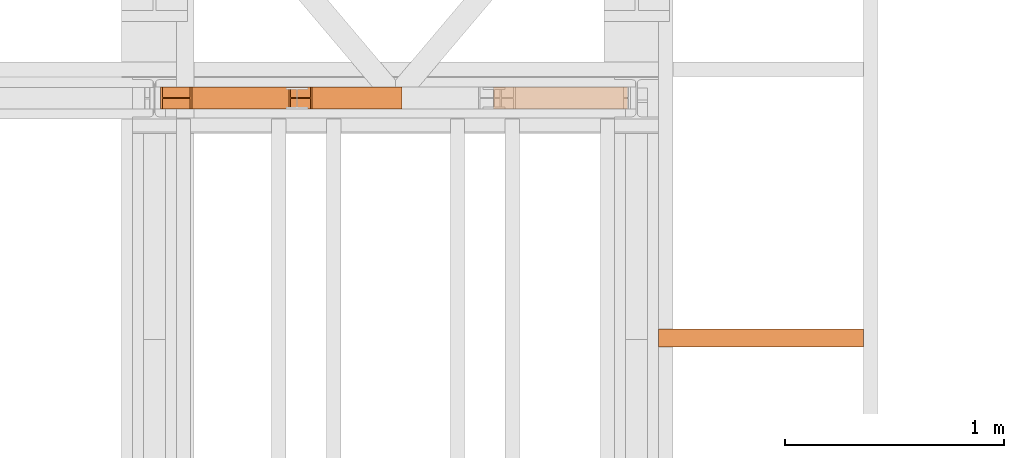
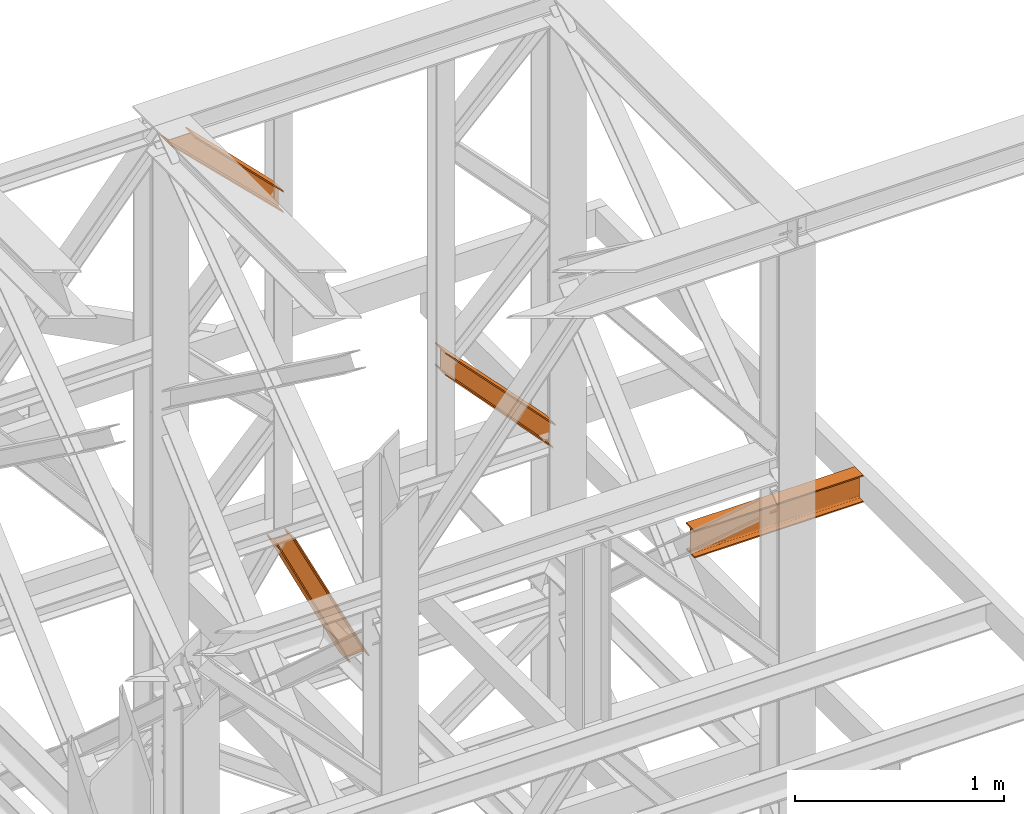
# One storey, part 206 of 208: 4 proxies.
"""IFC2X3 building model written with IfcOpenShell, lengths in millimetres."""

from ifc_helpers import new_model, entity, si_unit, converted_unit, frame, origin, origin_with_axes, place, context, subcontext, project, spatial, faceted_brep, element, save


model = new_model("IFC2X3")

# Units and contexts
model_context = context("Model", 3, precision=1e-05, world=origin())
plan_context = context("Plan", 3, precision=1e-05, world=origin())
body_context = subcontext(model_context, "Body", "Model", "MODEL_VIEW")
ifc_project = project(units=[si_unit("LENGTHUNIT", "METRE", prefix="MILLI"), converted_unit("PLANEANGLEUNIT", "DEGREE", entity("IfcPlaneAngleMeasure", 0.0174532925199433), si_unit("PLANEANGLEUNIT", "RADIAN"), dimensions=[0, 0, 0, 0, 0, 0, 0]), si_unit("AREAUNIT", "SQUARE_METRE"), si_unit("VOLUMEUNIT", "CUBIC_METRE")], contexts=[model_context, plan_context])

# Building, storey
building_placement = place(None, origin())
building = spatial("IfcBuilding", under=ifc_project, at=building_placement, CompositionType="COMPLEX")
storey_placement = place(building_placement, origin_with_axes())
storey = spatial("IfcBuildingStorey", under=building, at=storey_placement, Name="Geschoss", CompositionType="ELEMENT")

# Proxies
proxy_1_placement = place(storey_placement, frame((8140.754968528663, -13810.57439404318, 9738.383764068489), z_axis=(0.0, 0.0, 1.0), x_axis=(1.0, 0.0, 0.0)))
element("IfcBuildingElementProxy", 1, at=proxy_1_placement, inside=storey, context=body_context, shape_type="Brep", body=[
    faceted_brep([(609.3389392297795, 0.01000000000021828, 127.1336120970282), (0.01000000000203727, 0.01000000000021828, 762.0805165043985), (0.01000000000203727, 0.01000000000021828, 772.1793707618835), (610.1904194102481, 0.01000000000021828, 135.4554138886069), (610.1904194102481, 0.01000000000021828, 135.4554138886069), (0.01000000000203727, 0.01000000000021828, 772.1793707618835), (0.01000000000294676, 100.0100000000002, 772.1793707618799), (610.1904194102481, 100.0100000000002, 135.4554138886069), (610.1904194102481, 100.0100000000002, 135.4554138886069), (0.01000000000294676, 100.0100000000002, 772.1793707618799), (0.01000000000203727, 100.0100000000002, 762.0805165043985), (609.3389392297795, 100.0100000000002, 127.1336120970282), (609.3389392297795, 100.0100000000002, 127.1336120970282), (0.01000000000203727, 100.0100000000002, 762.0805165043985), (0.01000000000203727, 52.51000000000022, 762.0805165043985), (609.3389392297795, 52.51000000000022, 127.1336120970282), (609.3389392297795, 52.51000000000022, 127.1336120970282), (0.01000000000203727, 52.51000000000022, 762.0805165043985), (0.01000000000112777, 52.51000000000022, 645.5811508176976), (597.1830768457185, 52.51000000000022, 8.330286210673876), (597.1830768457185, 52.51000000000022, 8.330286210673876), (0.01000000000112777, 52.51000000000022, 645.5811508176976), (0.009999999999308784, 100.0100000000002, 645.5811508177048), (597.1830768457185, 100.0100000000002, 8.330286210677514), (597.1830768457185, 100.0100000000002, 8.330286210677514), (0.009999999999308784, 100.0100000000002, 645.5811508177048), (0.01000000000203727, 100.0100000000002, 635.4780302121417), (596.3317517382911, 100.0100000000002, 0.01000000000021828), (596.3317517382911, 100.0100000000002, 0.01000000000021828), (0.01000000000203727, 100.0100000000002, 635.4780302121417), (0.01000000000294676, 0.01000000000021828, 635.4780302121417), (596.3317517382911, 0.01000000000021828, 0.01000000000021828), (596.3317517382911, 0.01000000000021828, 0.01000000000021828), (0.01000000000294676, 0.01000000000021828, 635.4780302121417), (0.01000000000112777, 0.01000000000021828, 645.5811508177048), (597.1830768457185, 0.01000000000021828, 8.330286210677514), (597.1830768457185, 0.01000000000021828, 8.330286210677514), (0.01000000000112777, 0.01000000000021828, 645.5811508177048), (0.01000000000203727, 47.51000000000022, 645.5811508177048), (597.1830768457203, 47.51000000000022, 8.330286210681152), (597.1830768457203, 47.51000000000022, 8.330286210681152), (0.01000000000203727, 47.51000000000022, 645.5811508177048), (0.01000000000203727, 47.51000000000022, 762.0805165043985), (609.3389392297795, 47.51000000000022, 127.1336120970282), (609.3389392297795, 47.51000000000022, 127.1336120970282), (0.01000000000203727, 47.51000000000022, 762.0805165043985), (0.01000000000203727, 0.01000000000021828, 762.0805165043985), (609.3389392297795, 0.01000000000021828, 127.1336120970282), (610.1904194102481, 0.01000000000021828, 135.4554138886069), (610.1904194102481, 100.0100000000002, 135.4554138886069), (609.3389392297795, 100.0100000000002, 127.1336120970282), (609.3389392297795, 52.51000000000022, 127.1336120970282), (597.1830768457185, 52.51000000000022, 8.330286210673876), (597.1830768457185, 100.0100000000002, 8.330286210677514), (596.3317517382911, 100.0100000000002, 0.01000000000021828), (596.3317517382911, 0.01000000000021828, 0.01000000000021828), (597.1830768457185, 0.01000000000021828, 8.330286210677514), (597.1830768457203, 47.51000000000022, 8.330286210681152), (609.3389392297795, 47.51000000000022, 127.1336120970282), (609.3389392297795, 0.01000000000021828, 127.1336120970282), (0.01000000000203727, 0.01000000000021828, 762.0805165043985), (0.01000000000203727, 47.51000000000022, 762.0805165043985), (0.01000000000203727, 47.51000000000022, 645.5811508177048), (0.01000000000112777, 0.01000000000021828, 645.5811508177048), (0.01000000000294676, 0.01000000000021828, 635.4780302121417), (0.01000000000203727, 100.0100000000002, 635.4780302121417), (0.009999999999308784, 100.0100000000002, 645.5811508177048), (0.01000000000112777, 52.51000000000022, 645.5811508176976), (0.01000000000203727, 52.51000000000022, 762.0805165043985), (0.01000000000203727, 100.0100000000002, 762.0805165043985), (0.01000000000294676, 100.0100000000002, 772.1793707618799), (0.01000000000203727, 0.01000000000021828, 772.1793707618835)], [[[0, 1, 2, 3]], [[4, 5, 6, 7]], [[8, 9, 10, 11]], [[12, 13, 14, 15]], [[16, 17, 18, 19]], [[20, 21, 22, 23]], [[24, 25, 26, 27]], [[28, 29, 30, 31]], [[32, 33, 34, 35]], [[36, 37, 38, 39]], [[40, 41, 42, 43]], [[44, 45, 46, 47]], [[48, 49, 50, 51, 52, 53, 54, 55, 56, 57, 58, 59]], [[60, 61, 62, 63, 64, 65, 66, 67, 68, 69, 70, 71]]], orient=[[False], [False], [False], [False], [False], [False], [False], [False], [False], [False], [False], [False], [False], [False]]),
])
proxy_2_placement = place(storey_placement, frame((6621.102838478852, -13810.57439404318, 11640.28097264272), z_axis=(0.0, 0.0, 1.0), x_axis=(1.0, 0.0, 0.0)))
element("IfcBuildingElementProxy", 2, at=proxy_2_placement, inside=storey, context=body_context, shape_type="Brep", body=[
    faceted_brep([(134.4022503379219, 0.01000000000203727, 609.7190860510873), (143.6237680844633, 0.01000000000021828, 609.7190860510873), (622.1621300498164, 0.01000000000021828, 130.8127730178949), (622.1621300498164, 0.01000000000021828, 120.9016769489845), (143.6237680844633, 0.01000000000021828, 609.7190860510873), (143.6237680844643, 100.0100000000002, 609.7190860510873), (622.1621300498127, 100.0100000000002, 130.8127730179022), (622.1621300498164, 0.01000000000021828, 130.8127730178949), (143.6237680844643, 100.0100000000002, 609.7190860510873), (134.4022503379219, 100.0100000000002, 609.7190860510873), (622.1621300498164, 100.0100000000002, 120.9016769489845), (622.1621300498127, 100.0100000000002, 130.8127730179022), (134.4022503379219, 100.0100000000002, 609.7190860510873), (134.402250337921, 52.51000000000022, 609.7190860510873), (622.1621300498173, 52.51000000000022, 120.9016769489808), (622.1621300498164, 100.0100000000002, 120.9016769489845), (134.402250337921, 52.51000000000022, 609.7190860510873), (9.2316220054945, 52.51000000000022, 609.7190860510873), (622.1621300498164, 52.51000000000022, 9.871029833511784), (622.1621300498173, 52.51000000000022, 120.9016769489808), (9.2316220054945, 52.51000000000022, 609.7190860510873), (9.2316220054945, 100.0100000000002, 609.7190860510909), (622.1621300498164, 100.0100000000002, 9.871029833511784), (622.1621300498164, 52.51000000000022, 9.871029833511784), (9.2316220054945, 100.0100000000002, 609.7190860510909), (0.01000000000021828, 100.0100000000002, 609.7190860510909), (622.1621300498164, 100.0100000000002, 0.01000000000021828), (622.1621300498164, 100.0100000000002, 9.871029833511784), (0.01000000000021828, 100.0100000000002, 609.7190860510909), (0.01000000000476575, 0.01000000000021828, 609.7190860510837), (622.1621300498164, 0.01000000000021828, 0.01000000000021828), (622.1621300498164, 100.0100000000002, 0.01000000000021828), (0.01000000000476575, 0.01000000000021828, 609.7190860510837), (9.231622005500867, 0.01000000000203727, 609.7190860510873), (622.1621300498164, 0.01000000000021828, 9.871029833511784), (622.1621300498164, 0.01000000000021828, 0.01000000000021828), (9.231622005500867, 0.01000000000203727, 609.7190860510873), (9.231622005498139, 47.51000000000022, 609.7190860510909), (622.1621300498164, 47.51000000000022, 9.871029833511784), (622.1621300498164, 0.01000000000021828, 9.871029833511784), (9.231622005498139, 47.51000000000022, 609.7190860510909), (134.4022503379219, 47.51000000000022, 609.7190860510873), (622.1621300498164, 47.51000000000022, 120.9016769489845), (622.1621300498164, 47.51000000000022, 9.871029833511784), (134.4022503379219, 47.51000000000022, 609.7190860510873), (134.4022503379219, 0.01000000000203727, 609.7190860510873), (622.1621300498164, 0.01000000000021828, 120.9016769489845), (622.1621300498164, 47.51000000000022, 120.9016769489845), (622.1621300498164, 0.01000000000021828, 120.9016769489845), (622.1621300498164, 0.01000000000021828, 130.8127730178949), (622.1621300498127, 100.0100000000002, 130.8127730179022), (622.1621300498164, 100.0100000000002, 120.9016769489845), (622.1621300498173, 52.51000000000022, 120.9016769489808), (622.1621300498164, 52.51000000000022, 9.871029833511784), (622.1621300498164, 100.0100000000002, 9.871029833511784), (622.1621300498164, 100.0100000000002, 0.01000000000021828), (622.1621300498164, 0.01000000000021828, 0.01000000000021828), (622.1621300498164, 0.01000000000021828, 9.871029833511784), (622.1621300498164, 47.51000000000022, 9.871029833511784), (622.1621300498164, 47.51000000000022, 120.9016769489845), (143.6237680844633, 0.01000000000021828, 609.7190860510873), (134.4022503379219, 0.01000000000203727, 609.7190860510873), (134.4022503379219, 47.51000000000022, 609.7190860510873), (9.231622005498139, 47.51000000000022, 609.7190860510909), (9.231622005500867, 0.01000000000203727, 609.7190860510873), (0.01000000000476575, 0.01000000000021828, 609.7190860510837), (0.01000000000021828, 100.0100000000002, 609.7190860510909), (9.2316220054945, 100.0100000000002, 609.7190860510909), (9.2316220054945, 52.51000000000022, 609.7190860510873), (134.402250337921, 52.51000000000022, 609.7190860510873), (134.4022503379219, 100.0100000000002, 609.7190860510873), (143.6237680844643, 100.0100000000002, 609.7190860510873)], [[[0, 1, 2, 3]], [[4, 5, 6, 7]], [[8, 9, 10, 11]], [[12, 13, 14, 15]], [[16, 17, 18, 19]], [[20, 21, 22, 23]], [[24, 25, 26, 27]], [[28, 29, 30, 31]], [[32, 33, 34, 35]], [[36, 37, 38, 39]], [[40, 41, 42, 43]], [[44, 45, 46, 47]], [[48, 49, 50, 51, 52, 53, 54, 55, 56, 57, 58, 59]], [[60, 61, 62, 63, 64, 65, 66, 67, 68, 69, 70, 71]]], orient=[[False], [False], [False], [False], [False], [False], [False], [False], [False], [False], [False], [False], [False], [False]]),
])
proxy_3_placement = place(storey_placement, frame((7206.920491684339, -13810.57439404318, 8881.007354628784), z_axis=(0.0, 0.0, 1.0), x_axis=(1.0, 0.0, 0.0)))
element("IfcBuildingElementProxy", 3, at=proxy_3_placement, inside=storey, context=body_context, shape_type="Brep", body=[
    faceted_brep([(515.1363869069501, 0.01000000000021828, 0.01000000000021828), (507.9473177084756, 0.01000000000021828, 0.01000000000021828), (97.49508042920752, 0.01000000000021828, 829.1083585935612), (105.1910810543704, 0.01000000000021828, 829.1083585935612), (515.1363869069492, 100.0100000000002, 0.01000000000021828), (515.1363869069501, 0.01000000000021828, 0.01000000000021828), (105.1910810543704, 0.01000000000021828, 829.1083585935612), (105.1910810543668, 100.0100000000002, 829.1083585935612), (507.9473177084756, 100.0100000000002, 0.01000000000021828), (515.1363869069492, 100.0100000000002, 0.01000000000021828), (105.1910810543668, 100.0100000000002, 829.1083585935612), (97.49508042920752, 100.0100000000002, 829.1083585935612), (507.9473177084756, 52.51000000000022, 0.01000000000385626), (507.9473177084756, 100.0100000000002, 0.01000000000021828), (97.49508042920752, 100.0100000000002, 829.1083585935612), (97.49508042920752, 52.51000000000022, 829.1083585935612), (409.4818461420691, 52.51000000000022, 0.01000000000021828), (507.9473177084756, 52.51000000000022, 0.01000000000385626), (97.49508042920752, 52.51000000000022, 829.1083585935612), (7.688350677079143, 52.51000000000022, 829.1083585935612), (409.4818461420718, 100.0100000000002, 0.01000000000021828), (409.4818461420691, 52.51000000000022, 0.01000000000021828), (7.688350677079143, 52.51000000000022, 829.1083585935612), (7.688350677081871, 100.0100000000002, 829.1083585935612), (402.3010046401523, 100.0100000000002, 0.01000000000021828), (409.4818461420718, 100.0100000000002, 0.01000000000021828), (7.688350677081871, 100.0100000000002, 829.1083585935612), (0.01000000000021828, 100.0100000000002, 829.1083585935612), (402.3010046401523, 0.01000000000021828, 0.01000000000021828), (402.3010046401523, 100.0100000000002, 0.01000000000021828), (0.01000000000021828, 100.0100000000002, 829.1083585935612), (0.01000000000021828, 0.01000000000021828, 829.1083585935612), (409.4818461420718, 0.01000000000021828, 0.01000000000021828), (402.3010046401523, 0.01000000000021828, 0.01000000000021828), (0.01000000000021828, 0.01000000000021828, 829.1083585935612), (7.68835067708369, 0.01000000000021828, 829.1083585935612), (409.4818461420737, 47.51000000000022, 0.01000000000021828), (409.4818461420718, 0.01000000000021828, 0.01000000000021828), (7.68835067708369, 0.01000000000021828, 829.1083585935612), (7.68835067708369, 47.51000000000022, 829.1083585935612), (507.9473177084756, 47.51000000000022, 0.01000000000385626), (409.4818461420737, 47.51000000000022, 0.01000000000021828), (7.68835067708369, 47.51000000000022, 829.1083585935612), (97.49508042920752, 47.51000000000022, 829.1083585935612), (507.9473177084756, 0.01000000000021828, 0.01000000000021828), (507.9473177084756, 47.51000000000022, 0.01000000000385626), (97.49508042920752, 47.51000000000022, 829.1083585935612), (97.49508042920752, 0.01000000000021828, 829.1083585935612), (105.1910810543704, 0.01000000000021828, 829.1083585935612), (97.49508042920752, 0.01000000000021828, 829.1083585935612), (97.49508042920752, 47.51000000000022, 829.1083585935612), (7.68835067708369, 47.51000000000022, 829.1083585935612), (7.68835067708369, 0.01000000000021828, 829.1083585935612), (0.01000000000021828, 0.01000000000021828, 829.1083585935612), (0.01000000000021828, 100.0100000000002, 829.1083585935612), (7.688350677081871, 100.0100000000002, 829.1083585935612), (7.688350677079143, 52.51000000000022, 829.1083585935612), (97.49508042920752, 52.51000000000022, 829.1083585935612), (97.49508042920752, 100.0100000000002, 829.1083585935612), (105.1910810543668, 100.0100000000002, 829.1083585935612), (507.9473177084756, 0.01000000000021828, 0.01000000000021828), (515.1363869069501, 0.01000000000021828, 0.01000000000021828), (515.1363869069492, 100.0100000000002, 0.01000000000021828), (507.9473177084756, 100.0100000000002, 0.01000000000021828), (507.9473177084756, 52.51000000000022, 0.01000000000385626), (409.4818461420691, 52.51000000000022, 0.01000000000021828), (409.4818461420718, 100.0100000000002, 0.01000000000021828), (402.3010046401523, 100.0100000000002, 0.01000000000021828), (402.3010046401523, 0.01000000000021828, 0.01000000000021828), (409.4818461420718, 0.01000000000021828, 0.01000000000021828), (409.4818461420737, 47.51000000000022, 0.01000000000021828), (507.9473177084756, 47.51000000000022, 0.01000000000385626)], [[[0, 1, 2, 3]], [[4, 5, 6, 7]], [[8, 9, 10, 11]], [[12, 13, 14, 15]], [[16, 17, 18, 19]], [[20, 21, 22, 23]], [[24, 25, 26, 27]], [[28, 29, 30, 31]], [[32, 33, 34, 35]], [[36, 37, 38, 39]], [[40, 41, 42, 43]], [[44, 45, 46, 47]], [[48, 49, 50, 51, 52, 53, 54, 55, 56, 57, 58, 59]], [[60, 61, 62, 63, 64, 65, 66, 67, 68, 69, 70, 71]]], orient=[[False], [False], [False], [False], [False], [False], [False], [False], [False], [False], [False], [False], [False], [False]]),
])
proxy_4_placement = place(storey_placement, frame((8893.254970018783, -14896.48556403224, 9699.99), z_axis=(0.0, 0.0, 1.0), x_axis=(1.0, 0.0, 0.0)))
element("IfcBuildingElementProxy", 4, at=proxy_4_placement, inside=storey, context=body_context, shape_type="Brep", body=[
    faceted_brep([(934.7672634228275, 0.01000000000021828, 160.0100000000002), (0.01000000000021828, 0.01616250976258016, 160.0100000000002), (0.01000000000021828, 82.01616250976258, 160.0100000000002), (934.7672634228275, 82.01000000000022, 160.0100000000002), (934.7672634228275, 82.01000000000022, 160.0100000000002), (0.01000000000021828, 82.01616250976258, 160.0100000000002), (0.01000000000021828, 82.01616250976258, 152.6099999046328), (934.7672634228275, 82.01000000000022, 152.6099999046328), (934.7672634228275, 82.01000000000022, 152.6099999046328), (0.01000000000021828, 82.01616250976258, 152.6099999046328), (0.01000000000021828, 52.51616250976258, 152.6099999046328), (934.7672634228275, 52.51000000000022, 152.6099999046328), (934.7672634228275, 52.51000000000022, 152.6099999046328), (0.01000000000021828, 52.51616250976258, 152.6099999046328), (0.01000000000021828, 50.18679891617103, 152.3033059671343), (934.7672634228275, 50.18063640640685, 152.3033059671343), (934.7672634228275, 50.18063640640685, 152.3033059671343), (0.01000000000021828, 50.18679891617103, 152.3033059671343), (0.01000000000021828, 48.01617563491527, 151.4042043652353), (934.7672634228275, 48.01001312515109, 151.4042043652353), (934.7672634228275, 48.01001312515109, 151.4042043652353), (0.01000000000021828, 48.01617563491527, 151.4042043652353), (0.01000000000021828, 46.1522014790844, 149.973960935311), (934.7672634228275, 46.14603896932022, 149.973960935311), (934.7672634228275, 46.14603896932022, 149.973960935311), (0.01000000000021828, 46.1522014790844, 149.973960935311), (0.01000000000021828, 44.72195804915828, 148.1099867794801), (934.7672634228275, 44.71579553939409, 148.1099867794801), (934.7672634228275, 44.71579553939409, 148.1099867794801), (0.01000000000021828, 44.72195804915828, 148.1099867794801), (0.01000000000021828, 43.82285644726107, 145.9393634982243), (934.7672634228275, 43.81669393749689, 145.9393634982243), (934.7672634228275, 43.81669393749689, 145.9393634982243), (0.01000000000021828, 43.82285644726107, 145.9393634982243), (0.01000000000021828, 43.51616250976258, 143.6099999046328), (934.7672634228275, 43.51000000000022, 143.6099999046328), (934.7672634228275, 43.51000000000022, 143.6099999046328), (0.01000000000021828, 43.51616250976258, 143.6099999046328), (0.01000000000021828, 43.51616250976258, 16.41000009536765), (934.7672634228275, 43.51000000000022, 16.41000009536765), (934.7672634228275, 43.51000000000022, 16.41000009536765), (0.01000000000021828, 43.51616250976258, 16.41000009536765), (0.01000000000021828, 43.82285644726107, 14.08063650177428), (934.7672634228275, 43.81669393749689, 14.08063650177428), (934.7672634228275, 43.81669393749689, 14.08063650177428), (0.01000000000021828, 43.82285644726107, 14.08063650177428), (0.01000000000021828, 44.72195804915828, 11.91001322052034), (934.7672634228275, 44.71579553939409, 11.91001322052034), (934.7672634228275, 44.71579553939409, 11.91001322052034), (0.01000000000021828, 44.72195804915828, 11.91001322052034), (0.01000000000021828, 46.1522014790844, 10.04603906468765), (934.7672634228275, 46.14603896932022, 10.04603906468765), (934.7672634228275, 46.14603896932022, 10.04603906468765), (0.01000000000021828, 46.1522014790844, 10.04603906468765), (0.01000000000021828, 48.01617563491527, 8.615795634763344), (934.7672634228275, 48.01001312515109, 8.615795634763344), (934.7672634228275, 48.01001312515109, 8.615795634763344), (0.01000000000021828, 48.01617563491527, 8.615795634763344), (0.01000000000021828, 50.18679891617103, 7.716694032864325), (934.7672634228275, 50.18063640640685, 7.716694032864325), (934.7672634228275, 50.18063640640685, 7.716694032864325), (0.01000000000021828, 50.18679891617103, 7.716694032864325), (0.01000000000021828, 52.51616250976258, 7.41000009536765), (934.7672634228275, 52.51000000000022, 7.41000009536765), (934.7672634228275, 52.51000000000022, 7.41000009536765), (0.01000000000021828, 52.51616250976258, 7.41000009536765), (0.01000000000021828, 82.01616250976258, 7.41000009536765), (934.7672634228275, 82.01000000000022, 7.41000009536765), (934.7672634228275, 82.01000000000022, 7.41000009536765), (0.01000000000021828, 82.01616250976258, 7.41000009536765), (0.01000000000021828, 82.01616250976258, 0.01000000000021828), (934.7672634228275, 82.01000000000022, 0.01000000000021828), (934.7672634228275, 82.01000000000022, 0.01000000000021828), (0.01000000000021828, 82.01616250976258, 0.01000000000021828), (0.01000000000021828, 0.01616250976258016, 0.01000000000021828), (934.7672634228275, 0.01000000000021828, 0.01000000000021828), (934.7672634228275, 0.01000000000021828, 0.01000000000021828), (0.01000000000021828, 0.01616250976258016, 0.01000000000021828), (0.01000000000021828, 0.01616250976258016, 7.41000009536765), (934.7672634228275, 0.01000000000021828, 7.41000009536765), (934.7672634228275, 0.01000000000021828, 7.41000009536765), (0.01000000000021828, 0.01616250976258016, 7.41000009536765), (0.01000000000021828, 29.51616250976258, 7.41000009536765), (934.7672634228275, 29.51000000000022, 7.41000009536765), (934.7672634228275, 29.51000000000022, 7.41000009536765), (0.01000000000021828, 29.51616250976258, 7.41000009536765), (0.01000000000021828, 31.84552610335413, 7.716694032864325), (934.7672634228275, 31.83936359359177, 7.716694032864325), (934.7672634228275, 31.83936359359177, 7.716694032864325), (0.01000000000021828, 31.84552610335413, 7.716694032864325), (0.01000000000021828, 34.01614938460989, 8.615795634763344), (934.7672634228275, 34.00998687484571, 8.615795634763344), (934.7672634228275, 34.00998687484571, 8.615795634763344), (0.01000000000021828, 34.01614938460989, 8.615795634763344), (0.01000000000021828, 35.88012354044076, 10.04603906468765), (934.7672634228275, 35.8739610306784, 10.04603906468765), (934.7672634228275, 35.8739610306784, 10.04603906468765), (0.01000000000021828, 35.88012354044076, 10.04603906468765), (0.01000000000021828, 37.31036697036689, 11.91001322052034), (934.7672634228275, 37.30420446060271, 11.91001322052034), (934.7672634228275, 37.30420446060271, 11.91001322052034), (0.01000000000021828, 37.31036697036689, 11.91001322052034), (0.01000000000021828, 38.20946857226409, 14.08063650177428), (934.7672634228275, 38.20330606250172, 14.08063650177428), (934.7672634228275, 38.20330606250172, 14.08063650177428), (0.01000000000021828, 38.20946857226409, 14.08063650177428), (0.01000000000021828, 38.51616250976258, 16.41000009536765), (934.7672634228275, 38.51000000000022, 16.41000009536765), (934.7672634228275, 38.51000000000022, 16.41000009536765), (0.01000000000021828, 38.51616250976258, 16.41000009536765), (0.01000000000021828, 38.51616250976258, 143.6099999046328), (934.7672634228275, 38.51000000000022, 143.6099999046328), (934.7672634228275, 38.51000000000022, 143.6099999046328), (0.01000000000021828, 38.51616250976258, 143.6099999046328), (0.01000000000021828, 38.20946857226409, 145.9393634982243), (934.7672634228275, 38.20330606250172, 145.9393634982243), (934.7672634228275, 38.20330606250172, 145.9393634982243), (0.01000000000021828, 38.20946857226409, 145.9393634982243), (0.01000000000021828, 37.31036697036689, 148.1099867794801), (934.7672634228275, 37.30420446060271, 148.1099867794801), (934.7672634228275, 37.30420446060271, 148.1099867794801), (0.01000000000021828, 37.31036697036689, 148.1099867794801), (0.01000000000021828, 35.88012354044076, 149.973960935311), (934.7672634228275, 35.8739610306784, 149.973960935311), (934.7672634228275, 35.8739610306784, 149.973960935311), (0.01000000000021828, 35.88012354044076, 149.973960935311), (0.01000000000021828, 34.01614938460989, 151.4042043652353), (934.7672634228275, 34.00998687484571, 151.4042043652353), (934.7672634228275, 34.00998687484571, 151.4042043652353), (0.01000000000021828, 34.01614938460989, 151.4042043652353), (0.01000000000021828, 31.84552610335413, 152.3033059671343), (934.7672634228275, 31.83936359359177, 152.3033059671343), (934.7672634228275, 31.83936359359177, 152.3033059671343), (0.01000000000021828, 31.84552610335413, 152.3033059671343), (0.01000000000021828, 29.51616250976258, 152.6099999046328), (934.7672634228275, 29.51000000000022, 152.6099999046328), (934.7672634228275, 29.51000000000022, 152.6099999046328), (0.01000000000021828, 29.51616250976258, 152.6099999046328), (0.01000000000021828, 0.01616250976258016, 152.6099999046328), (934.7672634228275, 0.01000000000021828, 152.6099999046328), (934.7672634228275, 0.01000000000021828, 152.6099999046328), (0.01000000000021828, 0.01616250976258016, 152.6099999046328), (0.01000000000021828, 0.01616250976258016, 160.0100000000002), (934.7672634228275, 0.01000000000021828, 160.0100000000002), (934.7672634228275, 0.01000000000021828, 160.0100000000002), (934.7672634228275, 82.01000000000022, 160.0100000000002), (934.7672634228275, 82.01000000000022, 152.6099999046328), (934.7672634228275, 52.51000000000022, 152.6099999046328), (934.7672634228275, 50.18063640640685, 152.3033059671343), (934.7672634228275, 48.01001312515109, 151.4042043652353), (934.7672634228275, 46.14603896932022, 149.973960935311), (934.7672634228275, 44.71579553939409, 148.1099867794801), (934.7672634228275, 43.81669393749689, 145.9393634982243), (934.7672634228275, 43.51000000000022, 143.6099999046328), (934.7672634228275, 43.51000000000022, 16.41000009536765), (934.7672634228275, 43.81669393749689, 14.08063650177428), (934.7672634228275, 44.71579553939409, 11.91001322052034), (934.7672634228275, 46.14603896932022, 10.04603906468765), (934.7672634228275, 48.01001312515109, 8.615795634763344), (934.7672634228275, 50.18063640640685, 7.716694032864325), (934.7672634228275, 52.51000000000022, 7.41000009536765), (934.7672634228275, 82.01000000000022, 7.41000009536765), (934.7672634228275, 82.01000000000022, 0.01000000000021828), (934.7672634228275, 0.01000000000021828, 0.01000000000021828), (934.7672634228275, 0.01000000000021828, 7.41000009536765), (934.7672634228275, 29.51000000000022, 7.41000009536765), (934.7672634228275, 31.83936359359177, 7.716694032864325), (934.7672634228275, 34.00998687484571, 8.615795634763344), (934.7672634228275, 35.8739610306784, 10.04603906468765), (934.7672634228275, 37.30420446060271, 11.91001322052034), (934.7672634228275, 38.20330606250172, 14.08063650177428), (934.7672634228275, 38.51000000000022, 16.41000009536765), (934.7672634228275, 38.51000000000022, 143.6099999046328), (934.7672634228275, 38.20330606250172, 145.9393634982243), (934.7672634228275, 37.30420446060271, 148.1099867794801), (934.7672634228275, 35.8739610306784, 149.973960935311), (934.7672634228275, 34.00998687484571, 151.4042043652353), (934.7672634228275, 31.83936359359177, 152.3033059671343), (934.7672634228275, 29.51000000000022, 152.6099999046328), (934.7672634228275, 0.01000000000021828, 152.6099999046328), (0.01000000000021828, 0.01616250976258016, 160.0100000000002), (0.01000000000021828, 0.01616250976258016, 152.6099999046328), (0.01000000000021828, 29.51616250976258, 152.6099999046328), (0.01000000000021828, 31.84552610335413, 152.3033059671343), (0.01000000000021828, 34.01614938460989, 151.4042043652353), (0.01000000000021828, 35.88012354044076, 149.973960935311), (0.01000000000021828, 37.31036697036689, 148.1099867794801), (0.01000000000021828, 38.20946857226409, 145.9393634982243), (0.01000000000021828, 38.51616250976258, 143.6099999046328), (0.01000000000021828, 38.51616250976258, 16.41000009536765), (0.01000000000021828, 38.20946857226409, 14.08063650177428), (0.01000000000021828, 37.31036697036689, 11.91001322052034), (0.01000000000021828, 35.88012354044076, 10.04603906468765), (0.01000000000021828, 34.01614938460989, 8.615795634763344), (0.01000000000021828, 31.84552610335413, 7.716694032864325), (0.01000000000021828, 29.51616250976258, 7.41000009536765), (0.01000000000021828, 0.01616250976258016, 7.41000009536765), (0.01000000000021828, 0.01616250976258016, 0.01000000000021828), (0.01000000000021828, 82.01616250976258, 0.01000000000021828), (0.01000000000021828, 82.01616250976258, 7.41000009536765), (0.01000000000021828, 52.51616250976258, 7.41000009536765), (0.01000000000021828, 50.18679891617103, 7.716694032864325), (0.01000000000021828, 48.01617563491527, 8.615795634763344), (0.01000000000021828, 46.1522014790844, 10.04603906468765), (0.01000000000021828, 44.72195804915828, 11.91001322052034), (0.01000000000021828, 43.82285644726107, 14.08063650177428), (0.01000000000021828, 43.51616250976258, 16.41000009536765), (0.01000000000021828, 43.51616250976258, 143.6099999046328), (0.01000000000021828, 43.82285644726107, 145.9393634982243), (0.01000000000021828, 44.72195804915828, 148.1099867794801), (0.01000000000021828, 46.1522014790844, 149.973960935311), (0.01000000000021828, 48.01617563491527, 151.4042043652353), (0.01000000000021828, 50.18679891617103, 152.3033059671343), (0.01000000000021828, 52.51616250976258, 152.6099999046328), (0.01000000000021828, 82.01616250976258, 152.6099999046328), (0.01000000000021828, 82.01616250976258, 160.0100000000002)], [[[0, 1, 2, 3]], [[4, 5, 6, 7]], [[8, 9, 10, 11]], [[12, 13, 14, 15]], [[16, 17, 18, 19]], [[20, 21, 22, 23]], [[24, 25, 26, 27]], [[28, 29, 30, 31]], [[32, 33, 34, 35]], [[36, 37, 38, 39]], [[40, 41, 42, 43]], [[44, 45, 46, 47]], [[48, 49, 50, 51]], [[52, 53, 54, 55]], [[56, 57, 58, 59]], [[60, 61, 62, 63]], [[64, 65, 66, 67]], [[68, 69, 70, 71]], [[72, 73, 74, 75]], [[76, 77, 78, 79]], [[80, 81, 82, 83]], [[84, 85, 86, 87]], [[88, 89, 90, 91]], [[92, 93, 94, 95]], [[96, 97, 98, 99]], [[100, 101, 102, 103]], [[104, 105, 106, 107]], [[108, 109, 110, 111]], [[112, 113, 114, 115]], [[116, 117, 118, 119]], [[120, 121, 122, 123]], [[124, 125, 126, 127]], [[128, 129, 130, 131]], [[132, 133, 134, 135]], [[136, 137, 138, 139]], [[140, 141, 142, 143]], [[144, 145, 146, 147, 148, 149, 150, 151, 152, 153, 154, 155, 156, 157, 158, 159, 160, 161, 162, 163, 164, 165, 166, 167, 168, 169, 170, 171, 172, 173, 174, 175, 176, 177, 178, 179]], [[180, 181, 182, 183, 184, 185, 186, 187, 188, 189, 190, 191, 192, 193, 194, 195, 196, 197, 198, 199, 200, 201, 202, 203, 204, 205, 206, 207, 208, 209, 210, 211, 212, 213, 214, 215]]], orient=[[False], [False], [False], [False], [False], [False], [False], [False], [False], [False], [False], [False], [False], [False], [False], [False], [False], [False], [False], [False], [False], [False], [False], [False], [False], [False], [False], [False], [False], [False], [False], [False], [False], [False], [False], [False], [False], [False]]),
])

save(model, "model.ifc")
